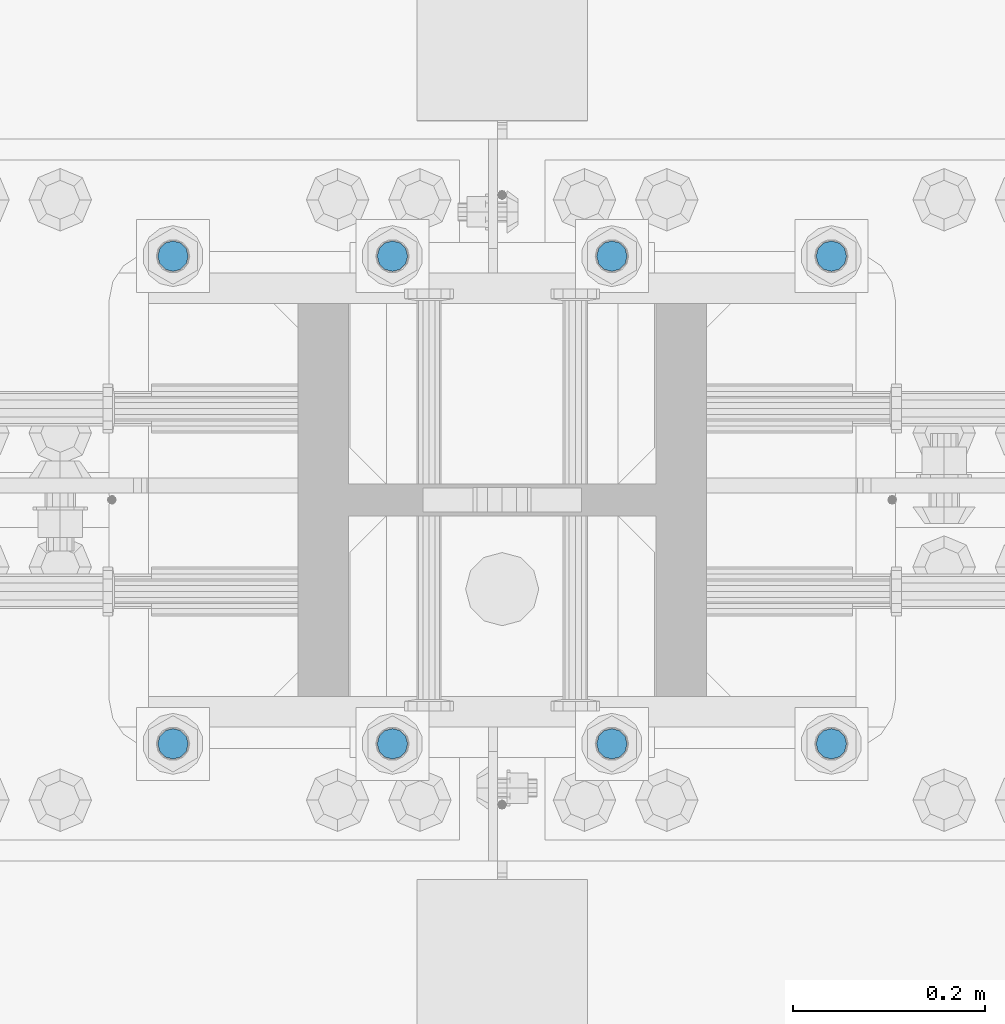
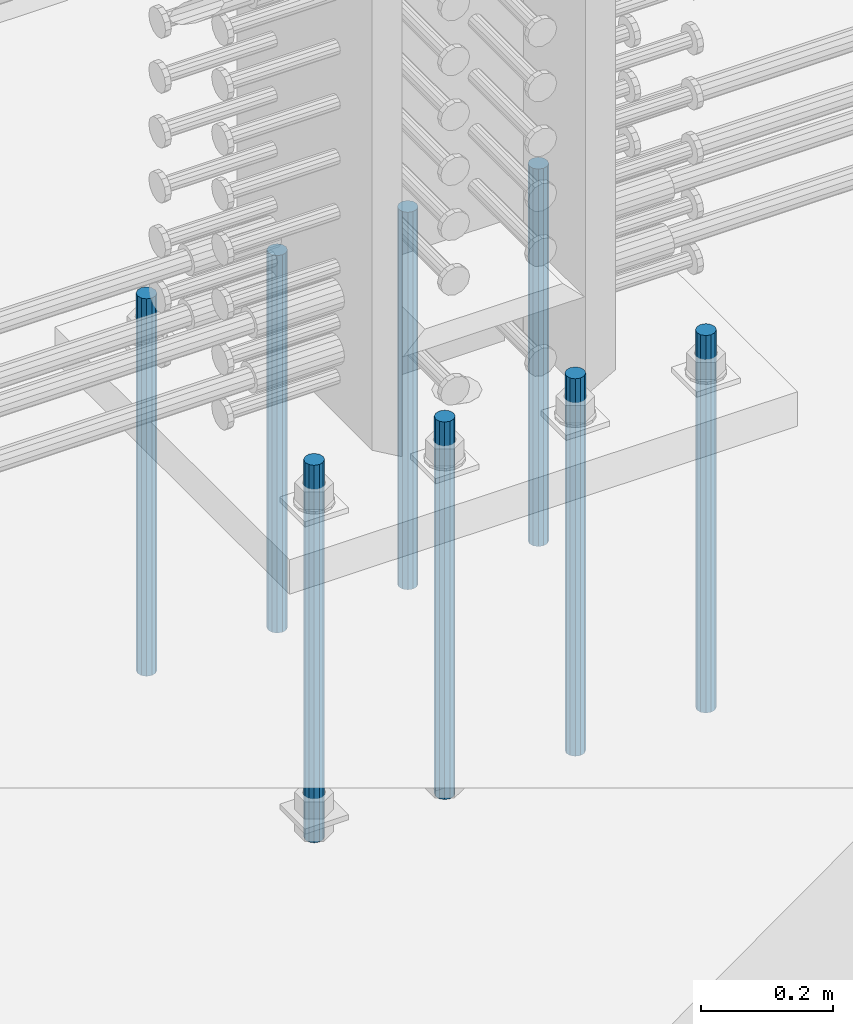
# One storey, part 933 of 1763: 8 columns, 1 element without a shape of its own.
"""IFC2X3 building model written with IfcOpenShell, lengths in millimetres."""

from ifc_helpers import new_model, si_unit, frame, origin_with_axes, place, context, subcontext, project, spatial, faceted_brep, material, type_object, element, aggregate, save


model = new_model("IFC2X3")

# Units and contexts
model_context = context("Model", 3, precision=1e-05, world=origin_with_axes())
body_context = subcontext(model_context, "Body", "Model", "MODEL_VIEW")
ifc_project = project(units=[si_unit("LENGTHUNIT", "METRE", prefix="MILLI"), si_unit("AREAUNIT", "SQUARE_METRE"), si_unit("VOLUMEUNIT", "CUBIC_METRE"), si_unit("MASSUNIT", "GRAM", prefix="KILO"), si_unit("TIMEUNIT", "SECOND"), si_unit("PLANEANGLEUNIT", "RADIAN"), si_unit("SOLIDANGLEUNIT", "STERADIAN"), si_unit("THERMODYNAMICTEMPERATUREUNIT", "DEGREE_CELSIUS"), si_unit("LUMINOUSINTENSITYUNIT", "LUMEN")], contexts=[model_context])

# Site, building, storey
site_placement = place(None, origin_with_axes())
site = spatial("IfcSite", under=ifc_project, at=site_placement, CompositionType="ELEMENT")
building_placement = place(site_placement, origin_with_axes())
building = spatial("IfcBuilding", under=site, at=building_placement, Name="Undefined", CompositionType="ELEMENT")
storey_placement = place(building_placement, origin_with_axes())
storey = spatial("IfcBuildingStorey", under=building, at=storey_placement, Name="Undefined", CompositionType="ELEMENT", Elevation=0.0)

# Assembly, columns
assembly_placement = place(storey_placement, origin_with_axes())
assembly = element("IfcElementAssembly", 1, at=assembly_placement, inside=storey, Name="TEMPLATE", AssemblyPlace="NOTDEFINED", PredefinedType="RIGID_FRAME")
ifc_material = material()
column_type = type_object("IfcColumnType", PredefinedType="NOTDEFINED")
column_1_placement = place(assembly_placement, frame((-61251.5372736986, 203.200000000006, 4000.5), z_axis=(1.0, 0.0, 0.0), x_axis=(0.0, 0.0, -1.0)))
column_1 = element("IfcColumn", 2, at=column_1_placement, type_object=column_type, material=ifc_material, Name="ALL THREADED ROD", context=body_context, shape_type="Brep", body=[
    faceted_brep([(0.0, -15.875, 0.0), (0.0, -13.7481532850798, -7.9375), (698.499, -13.7481532850798, -7.9375), (698.499, -15.875, 0.0), (0.0, -7.9375, -13.748153285078), (698.499, -7.9375, -13.748153285078), (4.91792532185561e-12, 0.0, -15.875), (698.499, 0.0, -15.875), (0.0, 7.9375, -13.748153285078), (698.499, 7.9375, -13.748153285078), (0.0, 13.7481532850798, -7.9375), (698.499, 13.7481532850798, -7.9375), (0.0, 15.875, 0.0), (698.499, 15.875, 0.0), (0.0, 13.7481532850798, 7.9375), (698.499, 13.7481532850798, 7.9375), (0.0, 7.9375, 13.748153285078), (698.499, 7.9375, 13.748153285078), (-1.64518337079051e-12, 0.0, 15.875), (698.499, 0.0, 15.875), (0.0, -7.9375, 13.748153285078), (698.499, -7.9375, 13.748153285078), (0.0, -13.7481532850798, 7.9375), (698.499, -13.7481532850798, 7.9375)], [[[0, 1, 2, 3]], [[1, 4, 5, 2]], [[4, 6, 7, 5]], [[6, 8, 9, 7]], [[8, 10, 11, 9]], [[10, 12, 13, 11]], [[12, 14, 15, 13]], [[14, 16, 17, 15]], [[16, 18, 19, 17]], [[18, 20, 21, 19]], [[20, 22, 23, 21]], [[22, 0, 3, 23]], [[5, 7, 9, 11, 13, 15, 17, 19, 21, 23, 3, 2]], [[22, 20, 18, 16, 14, 12, 10, 8, 6, 4, 1, 0]]]),
])
column_2_placement = place(assembly_placement, frame((-61251.5372736986, 711.200000000006, 4000.5), z_axis=(-1.0, 0.0, 0.0), x_axis=(0.0, 0.0, -1.0)))
column_2 = element("IfcColumn", 3, at=column_2_placement, type_object=column_type, material=ifc_material, Name="ALL THREADED ROD", context=body_context, shape_type="Brep", body=[
    faceted_brep([(0.0, -15.875, 0.0), (0.0, -13.7481532850798, -7.9375), (698.499, -13.7481532850798, -7.9375), (698.499, -15.875, 0.0), (0.0, -7.9375, -13.748153285078), (698.499, -7.9375, -13.748153285078), (4.91792532185561e-12, 0.0, -15.875), (698.499, 0.0, -15.875), (0.0, 7.9375, -13.748153285078), (698.499, 7.9375, -13.748153285078), (0.0, 13.7481532850798, -7.9375), (698.499, 13.7481532850798, -7.9375), (0.0, 15.875, 0.0), (698.499, 15.875, 0.0), (0.0, 13.7481532850798, 7.9375), (698.499, 13.7481532850798, 7.9375), (0.0, 7.9375, 13.748153285078), (698.499, 7.9375, 13.748153285078), (-1.64518337079051e-12, 0.0, 15.875), (698.499, 0.0, 15.875), (0.0, -7.9375, 13.748153285078), (698.499, -7.9375, 13.748153285078), (0.0, -13.7481532850798, 7.9375), (698.499, -13.7481532850798, 7.9375)], [[[0, 1, 2, 3]], [[1, 4, 5, 2]], [[4, 6, 7, 5]], [[6, 8, 9, 7]], [[8, 10, 11, 9]], [[10, 12, 13, 11]], [[12, 14, 15, 13]], [[14, 16, 17, 15]], [[16, 18, 19, 17]], [[18, 20, 21, 19]], [[20, 22, 23, 21]], [[22, 0, 3, 23]], [[5, 7, 9, 11, 13, 15, 17, 19, 21, 23, 3, 2]], [[22, 20, 18, 16, 14, 12, 10, 8, 6, 4, 1, 0]]]),
])
column_3_placement = place(assembly_placement, frame((-61480.1372736986, 203.200000000006, 4000.5), z_axis=(1.0, 0.0, 0.0), x_axis=(0.0, 0.0, -1.0)))
column_3 = element("IfcColumn", 4, at=column_3_placement, type_object=column_type, material=ifc_material, Name="ALL THREADED ROD", context=body_context, shape_type="Brep", body=[
    faceted_brep([(0.0, -15.875, 0.0), (0.0, -13.7481532850798, -7.9375), (698.499, -13.7481532850798, -7.9375), (698.499, -15.875, 0.0), (0.0, -7.9375, -13.748153285078), (698.499, -7.9375, -13.748153285078), (4.91792532185561e-12, 0.0, -15.875), (698.499, 0.0, -15.875), (0.0, 7.9375, -13.748153285078), (698.499, 7.9375, -13.748153285078), (0.0, 13.7481532850798, -7.9375), (698.499, 13.7481532850798, -7.9375), (0.0, 15.875, 0.0), (698.499, 15.875, 0.0), (0.0, 13.7481532850798, 7.9375), (698.499, 13.7481532850798, 7.9375), (0.0, 7.9375, 13.748153285078), (698.499, 7.9375, 13.748153285078), (-1.64518337079051e-12, 0.0, 15.875), (698.499, 0.0, 15.875), (0.0, -7.9375, 13.748153285078), (698.499, -7.9375, 13.748153285078), (0.0, -13.7481532850798, 7.9375), (698.499, -13.7481532850798, 7.9375)], [[[0, 1, 2, 3]], [[1, 4, 5, 2]], [[4, 6, 7, 5]], [[6, 8, 9, 7]], [[8, 10, 11, 9]], [[10, 12, 13, 11]], [[12, 14, 15, 13]], [[14, 16, 17, 15]], [[16, 18, 19, 17]], [[18, 20, 21, 19]], [[20, 22, 23, 21]], [[22, 0, 3, 23]], [[5, 7, 9, 11, 13, 15, 17, 19, 21, 23, 3, 2]], [[22, 20, 18, 16, 14, 12, 10, 8, 6, 4, 1, 0]]]),
])
column_4_placement = place(assembly_placement, frame((-61480.1372736986, 711.200000000006, 4000.5), z_axis=(-1.0, 0.0, 0.0), x_axis=(0.0, 0.0, -1.0)))
column_4 = element("IfcColumn", 5, at=column_4_placement, type_object=column_type, material=ifc_material, Name="ALL THREADED ROD", context=body_context, shape_type="Brep", body=[
    faceted_brep([(0.0, -15.875, 0.0), (0.0, -13.7481532850798, -7.9375), (698.499, -13.7481532850798, -7.9375), (698.499, -15.875, 0.0), (0.0, -7.9375, -13.748153285078), (698.499, -7.9375, -13.748153285078), (4.91792532185561e-12, 0.0, -15.875), (698.499, 0.0, -15.875), (0.0, 7.9375, -13.748153285078), (698.499, 7.9375, -13.748153285078), (0.0, 13.7481532850798, -7.9375), (698.499, 13.7481532850798, -7.9375), (0.0, 15.875, 0.0), (698.499, 15.875, 0.0), (0.0, 13.7481532850798, 7.9375), (698.499, 13.7481532850798, 7.9375), (0.0, 7.9375, 13.748153285078), (698.499, 7.9375, 13.748153285078), (-1.64518337079051e-12, 0.0, 15.875), (698.499, 0.0, 15.875), (0.0, -7.9375, 13.748153285078), (698.499, -7.9375, 13.748153285078), (0.0, -13.7481532850798, 7.9375), (698.499, -13.7481532850798, 7.9375)], [[[0, 1, 2, 3]], [[1, 4, 5, 2]], [[4, 6, 7, 5]], [[6, 8, 9, 7]], [[8, 10, 11, 9]], [[10, 12, 13, 11]], [[12, 14, 15, 13]], [[14, 16, 17, 15]], [[16, 18, 19, 17]], [[18, 20, 21, 19]], [[20, 22, 23, 21]], [[22, 0, 3, 23]], [[5, 7, 9, 11, 13, 15, 17, 19, 21, 23, 3, 2]], [[22, 20, 18, 16, 14, 12, 10, 8, 6, 4, 1, 0]]]),
])
column_5_placement = place(assembly_placement, frame((-61708.7372736986, 203.200000000006, 4000.5), z_axis=(1.0, 0.0, 0.0), x_axis=(0.0, 0.0, -1.0)))
column_5 = element("IfcColumn", 6, at=column_5_placement, type_object=column_type, material=ifc_material, Name="ALL THREADED ROD", context=body_context, shape_type="Brep", body=[
    faceted_brep([(0.0, -15.875, 0.0), (0.0, -13.7481532850798, -7.9375), (698.499, -13.7481532850798, -7.9375), (698.499, -15.875, 0.0), (0.0, -7.9375, -13.748153285078), (698.499, -7.9375, -13.748153285078), (4.91792532185561e-12, 0.0, -15.875), (698.499, 0.0, -15.875), (0.0, 7.9375, -13.748153285078), (698.499, 7.9375, -13.748153285078), (0.0, 13.7481532850798, -7.9375), (698.499, 13.7481532850798, -7.9375), (0.0, 15.875, 0.0), (698.499, 15.875, 0.0), (0.0, 13.7481532850798, 7.9375), (698.499, 13.7481532850798, 7.9375), (0.0, 7.9375, 13.748153285078), (698.499, 7.9375, 13.748153285078), (-1.64518337079051e-12, 0.0, 15.875), (698.499, 0.0, 15.875), (0.0, -7.9375, 13.748153285078), (698.499, -7.9375, 13.748153285078), (0.0, -13.7481532850798, 7.9375), (698.499, -13.7481532850798, 7.9375)], [[[0, 1, 2, 3]], [[1, 4, 5, 2]], [[4, 6, 7, 5]], [[6, 8, 9, 7]], [[8, 10, 11, 9]], [[10, 12, 13, 11]], [[12, 14, 15, 13]], [[14, 16, 17, 15]], [[16, 18, 19, 17]], [[18, 20, 21, 19]], [[20, 22, 23, 21]], [[22, 0, 3, 23]], [[5, 7, 9, 11, 13, 15, 17, 19, 21, 23, 3, 2]], [[22, 20, 18, 16, 14, 12, 10, 8, 6, 4, 1, 0]]]),
])
column_6_placement = place(assembly_placement, frame((-61708.7372736986, 711.200000000006, 4000.5), z_axis=(-1.0, 0.0, 0.0), x_axis=(0.0, 0.0, -1.0)))
column_6 = element("IfcColumn", 7, at=column_6_placement, type_object=column_type, material=ifc_material, Name="ALL THREADED ROD", context=body_context, shape_type="Brep", body=[
    faceted_brep([(0.0, -15.875, 0.0), (0.0, -13.7481532850798, -7.9375), (698.499, -13.7481532850798, -7.9375), (698.499, -15.875, 0.0), (0.0, -7.9375, -13.748153285078), (698.499, -7.9375, -13.748153285078), (4.91792532185561e-12, 0.0, -15.875), (698.499, 0.0, -15.875), (0.0, 7.9375, -13.748153285078), (698.499, 7.9375, -13.748153285078), (0.0, 13.7481532850798, -7.9375), (698.499, 13.7481532850798, -7.9375), (0.0, 15.875, 0.0), (698.499, 15.875, 0.0), (0.0, 13.7481532850798, 7.9375), (698.499, 13.7481532850798, 7.9375), (0.0, 7.9375, 13.748153285078), (698.499, 7.9375, 13.748153285078), (-1.64518337079051e-12, 0.0, 15.875), (698.499, 0.0, 15.875), (0.0, -7.9375, 13.748153285078), (698.499, -7.9375, 13.748153285078), (0.0, -13.7481532850798, 7.9375), (698.499, -13.7481532850798, 7.9375)], [[[0, 1, 2, 3]], [[1, 4, 5, 2]], [[4, 6, 7, 5]], [[6, 8, 9, 7]], [[8, 10, 11, 9]], [[10, 12, 13, 11]], [[12, 14, 15, 13]], [[14, 16, 17, 15]], [[16, 18, 19, 17]], [[18, 20, 21, 19]], [[20, 22, 23, 21]], [[22, 0, 3, 23]], [[5, 7, 9, 11, 13, 15, 17, 19, 21, 23, 3, 2]], [[22, 20, 18, 16, 14, 12, 10, 8, 6, 4, 1, 0]]]),
])
column_7_placement = place(assembly_placement, frame((-61937.3372736986, 203.200000000006, 4000.5), z_axis=(1.0, 0.0, 0.0), x_axis=(0.0, 0.0, -1.0)))
column_7 = element("IfcColumn", 8, at=column_7_placement, type_object=column_type, material=ifc_material, Name="ALL THREADED ROD", context=body_context, shape_type="Brep", body=[
    faceted_brep([(0.0, -15.875, 0.0), (0.0, -13.7481532850798, -7.9375), (698.499, -13.7481532850798, -7.9375), (698.499, -15.875, 0.0), (0.0, -7.9375, -13.748153285078), (698.499, -7.9375, -13.748153285078), (4.91792532185561e-12, 0.0, -15.875), (698.499, 0.0, -15.875), (0.0, 7.9375, -13.748153285078), (698.499, 7.9375, -13.748153285078), (0.0, 13.7481532850798, -7.9375), (698.499, 13.7481532850798, -7.9375), (0.0, 15.875, 0.0), (698.499, 15.875, 0.0), (0.0, 13.7481532850798, 7.9375), (698.499, 13.7481532850798, 7.9375), (0.0, 7.9375, 13.748153285078), (698.499, 7.9375, 13.748153285078), (-1.64518337079051e-12, 0.0, 15.875), (698.499, 0.0, 15.875), (0.0, -7.9375, 13.748153285078), (698.499, -7.9375, 13.748153285078), (0.0, -13.7481532850798, 7.9375), (698.499, -13.7481532850798, 7.9375)], [[[0, 1, 2, 3]], [[1, 4, 5, 2]], [[4, 6, 7, 5]], [[6, 8, 9, 7]], [[8, 10, 11, 9]], [[10, 12, 13, 11]], [[12, 14, 15, 13]], [[14, 16, 17, 15]], [[16, 18, 19, 17]], [[18, 20, 21, 19]], [[20, 22, 23, 21]], [[22, 0, 3, 23]], [[5, 7, 9, 11, 13, 15, 17, 19, 21, 23, 3, 2]], [[22, 20, 18, 16, 14, 12, 10, 8, 6, 4, 1, 0]]]),
])
column_8_placement = place(assembly_placement, frame((-61937.3372736986, 711.200000000006, 4000.5), z_axis=(-1.0, 0.0, 0.0), x_axis=(0.0, 0.0, -1.0)))
column_8 = element("IfcColumn", 9, at=column_8_placement, type_object=column_type, material=ifc_material, Name="ALL THREADED ROD", context=body_context, shape_type="Brep", body=[
    faceted_brep([(0.0, -15.875, 0.0), (0.0, -13.7481532850798, -7.9375), (698.499, -13.7481532850798, -7.9375), (698.499, -15.875, 0.0), (0.0, -7.9375, -13.748153285078), (698.499, -7.9375, -13.748153285078), (4.91792532185561e-12, 0.0, -15.875), (698.499, 0.0, -15.875), (0.0, 7.9375, -13.748153285078), (698.499, 7.9375, -13.748153285078), (0.0, 13.7481532850798, -7.9375), (698.499, 13.7481532850798, -7.9375), (0.0, 15.875, 0.0), (698.499, 15.875, 0.0), (0.0, 13.7481532850798, 7.9375), (698.499, 13.7481532850798, 7.9375), (0.0, 7.9375, 13.748153285078), (698.499, 7.9375, 13.748153285078), (-1.64518337079051e-12, 0.0, 15.875), (698.499, 0.0, 15.875), (0.0, -7.9375, 13.748153285078), (698.499, -7.9375, 13.748153285078), (0.0, -13.7481532850798, 7.9375), (698.499, -13.7481532850798, 7.9375)], [[[0, 1, 2, 3]], [[1, 4, 5, 2]], [[4, 6, 7, 5]], [[6, 8, 9, 7]], [[8, 10, 11, 9]], [[10, 12, 13, 11]], [[12, 14, 15, 13]], [[14, 16, 17, 15]], [[16, 18, 19, 17]], [[18, 20, 21, 19]], [[20, 22, 23, 21]], [[22, 0, 3, 23]], [[5, 7, 9, 11, 13, 15, 17, 19, 21, 23, 3, 2]], [[22, 20, 18, 16, 14, 12, 10, 8, 6, 4, 1, 0]]]),
])
aggregate(assembly, [column_1, column_2, column_3, column_4, column_5, column_6, column_7, column_8])

save(model, "model.ifc")
